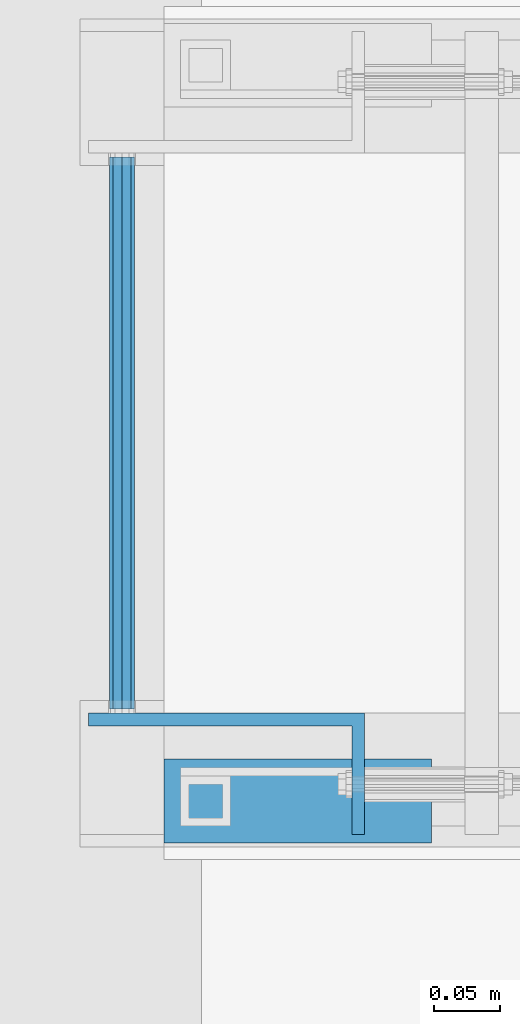
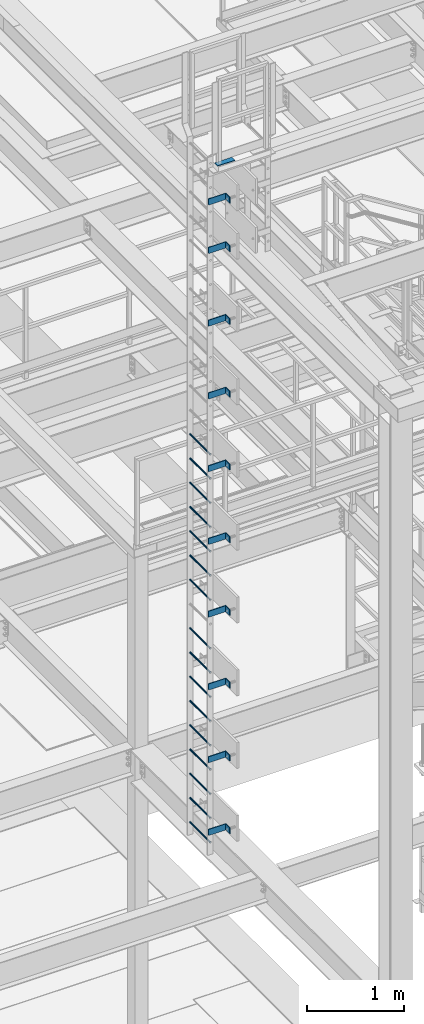
# One storey, part 2056 of 3843: 27 beams, 2 elements without a shape of their own.
"""IFC2X3 building model written with IfcOpenShell, lengths in millimetres."""

from ifc_helpers import new_model, si_unit, frame, origin_with_axes, place, context, subcontext, project, spatial, faceted_brep, material, type_object, element, aggregate, save


model = new_model("IFC2X3")

# Units and contexts
model_context = context("Model", 3, precision=1e-05, world=origin_with_axes())
body_context = subcontext(model_context, "Body", "Model", "MODEL_VIEW")
ifc_project = project(units=[si_unit("LENGTHUNIT", "METRE", prefix="MILLI"), si_unit("AREAUNIT", "SQUARE_METRE"), si_unit("VOLUMEUNIT", "CUBIC_METRE"), si_unit("MASSUNIT", "GRAM", prefix="KILO"), si_unit("TIMEUNIT", "SECOND"), si_unit("PLANEANGLEUNIT", "RADIAN"), si_unit("SOLIDANGLEUNIT", "STERADIAN"), si_unit("THERMODYNAMICTEMPERATUREUNIT", "DEGREE_CELSIUS"), si_unit("LUMINOUSINTENSITYUNIT", "LUMEN")], contexts=[model_context])

# Site, building, storey
site_placement = place(None, origin_with_axes())
site = spatial("IfcSite", under=ifc_project, at=site_placement, CompositionType="ELEMENT")
building_placement = place(site_placement, origin_with_axes())
building = spatial("IfcBuilding", under=site, at=building_placement, Name="Undefined", CompositionType="ELEMENT")
storey_placement = place(building_placement, origin_with_axes())
storey = spatial("IfcBuildingStorey", under=building, at=storey_placement, Name="Undefined", CompositionType="ELEMENT", Elevation=0.0)

# Assembly, beams
assembly_1_placement = place(storey_placement, origin_with_axes())
assembly_1 = element("IfcElementAssembly", 1, at=assembly_1_placement, inside=storey, Name="LADDER", AssemblyPlace="NOTDEFINED", PredefinedType="RIGID_FRAME")
ifc_material_1 = material(Name="STEEL/A36")
beam_type_1 = type_object("IfcBeamType", PredefinedType="NOTDEFINED")
beam_1_placement = place(assembly_1_placement, frame((48180.624987793, 17435.5125, 43630.85), z_axis=(0.0, 0.0, 1.0), x_axis=(1.0, 0.0, 0.0)))
beam_1 = element("IfcBeam", 2, at=beam_1_placement, type_object=beam_type_1, material=ifc_material_1, Name="BENT_PLATE", context=body_context, shape_type="Brep", body=[
    faceted_brep([(0.0, -4.76250000000073, -38.0999999999985), (0.0, -4.76250000000073, 38.0999999999985), (0.0, 4.76250000000073, 38.0999999999985), (0.0, 4.76250000000073, -38.0999999999985), (209.549999999996, 4.76249999999345, 38.0999999999985), (209.549999999996, 4.76249999999345, -38.0999999999985), (200.024999999994, -4.762500000008, -38.0999999999985), (200.024999999994, -4.762500000008, 38.0999999999985), (209.549999999996, -87.3125, 38.0999999999985), (209.549999999996, -87.3125, -38.0999999999985), (200.024999999994, -87.3125, 38.0999999999985), (200.024999999994, -87.3125, -38.0999999999985)], [[[0, 1, 2, 3]], [[3, 2, 4, 5]], [[1, 0, 6, 7]], [[5, 4, 8, 9]], [[4, 2, 1, 7, 10, 8]], [[7, 6, 11, 10]], [[6, 0, 3, 5, 9, 11]], [[10, 11, 9, 8]]]),
])
beam_2_placement = place(assembly_1_placement, frame((48180.6249877929, 17435.5125, 43021.25), z_axis=(0.0, 0.0, 1.0), x_axis=(1.0, 0.0, 0.0)))
beam_2 = element("IfcBeam", 3, at=beam_2_placement, type_object=beam_type_1, material=ifc_material_1, Name="BENT_PLATE", context=body_context, shape_type="Brep", body=[
    faceted_brep([(0.0, -4.76250000000073, -38.0999999999985), (0.0, -4.76250000000073, 38.0999999999985), (0.0, 4.76250000000073, 38.0999999999985), (0.0, 4.76250000000073, -38.0999999999985), (209.549999999996, 4.76249999999345, 38.0999999999985), (209.549999999996, 4.76249999999345, -38.0999999999985), (200.024999999994, -4.762500000008, -38.0999999999985), (200.024999999994, -4.762500000008, 38.0999999999985), (209.549999999996, -87.3125, 38.0999999999985), (209.549999999996, -87.3125, -38.0999999999985), (200.024999999994, -87.3125, 38.0999999999985), (200.024999999994, -87.3125, -38.0999999999985)], [[[0, 1, 2, 3]], [[3, 2, 4, 5]], [[1, 0, 6, 7]], [[5, 4, 8, 9]], [[4, 2, 1, 7, 10, 8]], [[7, 6, 11, 10]], [[6, 0, 3, 5, 9, 11]], [[10, 11, 9, 8]]]),
])
beam_3_placement = place(assembly_1_placement, frame((48180.6249877929, 17435.5125, 42106.85), z_axis=(0.0, 0.0, 1.0), x_axis=(1.0, 0.0, 0.0)))
beam_3 = element("IfcBeam", 4, at=beam_3_placement, type_object=beam_type_1, material=ifc_material_1, Name="BENT_PLATE", context=body_context, shape_type="Brep", body=[
    faceted_brep([(0.0, -4.76250000000073, -38.0999999999985), (0.0, -4.76250000000073, 38.0999999999985), (0.0, 4.76250000000073, 38.0999999999985), (0.0, 4.76250000000073, -38.0999999999985), (209.549999999996, 4.76249999999345, 38.0999999999985), (209.549999999996, 4.76249999999345, -38.0999999999985), (200.024999999994, -4.762500000008, -38.0999999999985), (200.024999999994, -4.762500000008, 38.0999999999985), (209.549999999996, -87.3125, 38.0999999999985), (209.549999999996, -87.3125, -38.0999999999985), (200.024999999994, -87.3125, 38.0999999999985), (200.024999999994, -87.3125, -38.0999999999985)], [[[0, 1, 2, 3]], [[3, 2, 4, 5]], [[1, 0, 6, 7]], [[5, 4, 8, 9]], [[4, 2, 1, 7, 10, 8]], [[7, 6, 11, 10]], [[6, 0, 3, 5, 9, 11]], [[10, 11, 9, 8]]]),
])
beam_4_placement = place(assembly_1_placement, frame((48180.6249877929, 17435.5125, 41192.45), z_axis=(0.0, 0.0, 1.0), x_axis=(1.0, 0.0, 0.0)))
beam_4 = element("IfcBeam", 5, at=beam_4_placement, type_object=beam_type_1, material=ifc_material_1, Name="BENT_PLATE", context=body_context, shape_type="Brep", body=[
    faceted_brep([(0.0, -4.76250000000073, -38.0999999999985), (0.0, -4.76250000000073, 38.0999999999985), (0.0, 4.76250000000073, 38.0999999999985), (0.0, 4.76250000000073, -38.0999999999985), (209.549999999996, 4.76249999999345, 38.0999999999985), (209.549999999996, 4.76249999999345, -38.0999999999985), (200.024999999994, -4.762500000008, -38.0999999999985), (200.024999999994, -4.762500000008, 38.0999999999985), (209.549999999996, -87.3125, 38.0999999999985), (209.549999999996, -87.3125, -38.0999999999985), (200.024999999994, -87.3125, 38.0999999999985), (200.024999999994, -87.3125, -38.0999999999985)], [[[0, 1, 2, 3]], [[3, 2, 4, 5]], [[1, 0, 6, 7]], [[5, 4, 8, 9]], [[4, 2, 1, 7, 10, 8]], [[7, 6, 11, 10]], [[6, 0, 3, 5, 9, 11]], [[10, 11, 9, 8]]]),
])
beam_5_placement = place(assembly_1_placement, frame((48180.6249877929, 17435.5125, 40278.05), z_axis=(0.0, 0.0, 1.0), x_axis=(1.0, 0.0, 0.0)))
beam_5 = element("IfcBeam", 6, at=beam_5_placement, type_object=beam_type_1, material=ifc_material_1, Name="BENT_PLATE", context=body_context, shape_type="Brep", body=[
    faceted_brep([(0.0, -4.76250000000073, -38.0999999999985), (0.0, -4.76250000000073, 38.0999999999985), (0.0, 4.76250000000073, 38.0999999999985), (0.0, 4.76250000000073, -38.0999999999985), (209.549999999996, 4.76249999999345, 38.0999999999985), (209.549999999996, 4.76249999999345, -38.0999999999985), (200.024999999994, -4.762500000008, -38.0999999999985), (200.024999999994, -4.762500000008, 38.0999999999985), (209.549999999996, -87.3125, 38.0999999999985), (209.549999999996, -87.3125, -38.0999999999985), (200.024999999994, -87.3125, 38.0999999999985), (200.024999999994, -87.3125, -38.0999999999985)], [[[0, 1, 2, 3]], [[3, 2, 4, 5]], [[1, 0, 6, 7]], [[5, 4, 8, 9]], [[4, 2, 1, 7, 10, 8]], [[7, 6, 11, 10]], [[6, 0, 3, 5, 9, 11]], [[10, 11, 9, 8]]]),
])
beam_6_placement = place(assembly_1_placement, frame((48180.6249877929, 17435.5125, 39363.65), z_axis=(0.0, 0.0, 1.0), x_axis=(1.0, 0.0, 0.0)))
beam_6 = element("IfcBeam", 7, at=beam_6_placement, type_object=beam_type_1, material=ifc_material_1, Name="BENT_PLATE", context=body_context, shape_type="Brep", body=[
    faceted_brep([(0.0, -4.76250000000073, -38.0999999999985), (0.0, -4.76250000000073, 38.0999999999985), (0.0, 4.76250000000073, 38.0999999999985), (0.0, 4.76250000000073, -38.0999999999985), (209.549999999996, 4.76249999999345, 38.0999999999985), (209.549999999996, 4.76249999999345, -38.0999999999985), (200.024999999994, -4.762500000008, -38.0999999999985), (200.024999999994, -4.762500000008, 38.0999999999985), (209.549999999996, -87.3125, 38.0999999999985), (209.549999999996, -87.3125, -38.0999999999985), (200.024999999994, -87.3125, 38.0999999999985), (200.024999999994, -87.3125, -38.0999999999985)], [[[0, 1, 2, 3]], [[3, 2, 4, 5]], [[1, 0, 6, 7]], [[5, 4, 8, 9]], [[4, 2, 1, 7, 10, 8]], [[7, 6, 11, 10]], [[6, 0, 3, 5, 9, 11]], [[10, 11, 9, 8]]]),
])
beam_7_placement = place(assembly_1_placement, frame((48180.6249877929, 17435.5125, 38449.25), z_axis=(0.0, 0.0, 1.0), x_axis=(1.0, 0.0, 0.0)))
beam_7 = element("IfcBeam", 8, at=beam_7_placement, type_object=beam_type_1, material=ifc_material_1, Name="BENT_PLATE", context=body_context, shape_type="Brep", body=[
    faceted_brep([(0.0, -4.76250000000073, -38.0999999999985), (0.0, -4.76250000000073, 38.0999999999985), (0.0, 4.76250000000073, 38.0999999999985), (0.0, 4.76250000000073, -38.0999999999985), (209.549999999996, 4.76249999999345, 38.0999999999985), (209.549999999996, 4.76249999999345, -38.0999999999985), (200.024999999994, -4.762500000008, -38.0999999999985), (200.024999999994, -4.762500000008, 38.0999999999985), (209.549999999996, -87.3125, 38.0999999999985), (209.549999999996, -87.3125, -38.0999999999985), (200.024999999994, -87.3125, 38.0999999999985), (200.024999999994, -87.3125, -38.0999999999985)], [[[0, 1, 2, 3]], [[3, 2, 4, 5]], [[1, 0, 6, 7]], [[5, 4, 8, 9]], [[4, 2, 1, 7, 10, 8]], [[7, 6, 11, 10]], [[6, 0, 3, 5, 9, 11]], [[10, 11, 9, 8]]]),
])
beam_8_placement = place(assembly_1_placement, frame((48180.6249877929, 17435.5125, 37534.85), z_axis=(0.0, 0.0, 1.0), x_axis=(1.0, 0.0, 0.0)))
beam_8 = element("IfcBeam", 9, at=beam_8_placement, type_object=beam_type_1, material=ifc_material_1, Name="BENT_PLATE", context=body_context, shape_type="Brep", body=[
    faceted_brep([(0.0, -4.76250000000073, -38.0999999999985), (0.0, -4.76250000000073, 38.0999999999985), (0.0, 4.76250000000073, 38.0999999999985), (0.0, 4.76250000000073, -38.0999999999985), (209.549999999996, 4.76249999999345, 38.0999999999985), (209.549999999996, 4.76249999999345, -38.0999999999985), (200.024999999994, -4.762500000008, -38.0999999999985), (200.024999999994, -4.762500000008, 38.0999999999985), (209.549999999996, -87.3125, 38.0999999999985), (209.549999999996, -87.3125, -38.0999999999985), (200.024999999994, -87.3125, 38.0999999999985), (200.024999999994, -87.3125, -38.0999999999985)], [[[0, 1, 2, 3]], [[3, 2, 4, 5]], [[1, 0, 6, 7]], [[5, 4, 8, 9]], [[4, 2, 1, 7, 10, 8]], [[7, 6, 11, 10]], [[6, 0, 3, 5, 9, 11]], [[10, 11, 9, 8]]]),
])
beam_9_placement = place(assembly_1_placement, frame((48180.6249877929, 17435.5125, 36620.45), z_axis=(0.0, 0.0, 1.0), x_axis=(1.0, 0.0, 0.0)))
beam_9 = element("IfcBeam", 10, at=beam_9_placement, type_object=beam_type_1, material=ifc_material_1, Name="BENT_PLATE", context=body_context, shape_type="Brep", body=[
    faceted_brep([(0.0, -4.76250000000073, -38.0999999999985), (0.0, -4.76250000000073, 38.0999999999985), (0.0, 4.76250000000073, 38.0999999999985), (0.0, 4.76250000000073, -38.0999999999985), (209.549999999996, 4.76249999999345, 38.0999999999985), (209.549999999996, 4.76249999999345, -38.0999999999985), (200.024999999994, -4.762500000008, -38.0999999999985), (200.024999999994, -4.762500000008, 38.0999999999985), (209.549999999996, -87.3125, 38.0999999999985), (209.549999999996, -87.3125, -38.0999999999985), (200.024999999994, -87.3125, 38.0999999999985), (200.024999999994, -87.3125, -38.0999999999985)], [[[0, 1, 2, 3]], [[3, 2, 4, 5]], [[1, 0, 6, 7]], [[5, 4, 8, 9]], [[4, 2, 1, 7, 10, 8]], [[7, 6, 11, 10]], [[6, 0, 3, 5, 9, 11]], [[10, 11, 9, 8]]]),
])
beam_10_placement = place(assembly_1_placement, frame((48180.6249877929, 17435.5125, 35706.05), z_axis=(0.0, 0.0, 1.0), x_axis=(1.0, 0.0, 0.0)))
beam_10 = element("IfcBeam", 11, at=beam_10_placement, type_object=beam_type_1, material=ifc_material_1, Name="BENT_PLATE", context=body_context, shape_type="Brep", body=[
    faceted_brep([(0.0, -4.76250000000073, -38.0999999999985), (0.0, -4.76250000000073, 38.0999999999985), (0.0, 4.76250000000073, 38.0999999999985), (0.0, 4.76250000000073, -38.0999999999985), (209.549999999996, 4.76249999999345, 38.0999999999985), (209.549999999996, 4.76249999999345, -38.0999999999985), (200.024999999994, -4.762500000008, -38.0999999999985), (200.024999999994, -4.762500000008, 38.0999999999985), (209.549999999996, -87.3125, 38.0999999999985), (209.549999999996, -87.3125, -38.0999999999985), (200.024999999994, -87.3125, 38.0999999999985), (200.024999999994, -87.3125, -38.0999999999985)], [[[0, 1, 2, 3]], [[3, 2, 4, 5]], [[1, 0, 6, 7]], [[5, 4, 8, 9]], [[4, 2, 1, 7, 10, 8]], [[7, 6, 11, 10]], [[6, 0, 3, 5, 9, 11]], [[10, 11, 9, 8]]]),
])
ifc_material_2 = material(Name="STEEL/A572-50")
beam_type_2 = type_object("IfcBeamType", PredefinedType="NOTDEFINED")
beam_11_placement = place(assembly_1_placement, frame((48206.024987793, 17862.55, 35569.525), z_axis=(1.0, 0.0, 0.0), x_axis=(0.0, -1.0, 0.0)))
beam_11 = element("IfcBeam", 12, at=beam_11_placement, type_object=beam_type_2, material=ifc_material_2, Name="RUNG", context=body_context, shape_type="Brep", body=[
    faceted_brep([(0.0, -9.52500000000146, 0.0), (0.0, -6.73519209080405, -6.73519209079677), (419.100000000006, -6.73519209080405, -6.73519209079677), (419.100000000006, -9.52500000000146, 0.0), (2.95075507493764e-12, 2.91322521661641e-12, -9.52499961853027), (419.100000000006, 0.0, -9.52499999999418), (0.0, 6.73519209080405, -6.73519209079677), (419.100000000006, 6.73519209080405, -6.73519209079677), (0.0, 9.52500000000146, 0.0), (419.100000000006, 9.52500000000146, 0.0), (0.0, 6.73519209080405, 6.73519209079677), (419.100000000006, 6.73519209080405, 6.73519209079677), (-9.87109982941227e-13, 2.91322521661641e-12, 9.52499961853027), (419.100000000006, 0.0, 9.52499999999418), (0.0, -6.73519209080405, 6.73519209079677), (419.100000000006, -6.73519209080405, 6.73519209079677)], [[[0, 1, 2, 3]], [[1, 4, 5, 2]], [[4, 6, 7, 5]], [[6, 8, 9, 7]], [[8, 10, 11, 9]], [[10, 12, 13, 11]], [[12, 14, 15, 13]], [[14, 0, 3, 15]], [[5, 7, 9, 11, 13, 15, 3, 2]], [[14, 12, 10, 8, 6, 4, 1, 0]]]),
])
beam_12_placement = place(assembly_1_placement, frame((48206.024987793, 17862.55, 35874.325), z_axis=(1.0, 0.0, 0.0), x_axis=(0.0, -1.0, 0.0)))
beam_12 = element("IfcBeam", 13, at=beam_12_placement, type_object=beam_type_2, material=ifc_material_2, Name="RUNG", context=body_context, shape_type="Brep", body=[
    faceted_brep([(0.0, -9.52500000000146, 0.0), (0.0, -6.73519209080405, -6.73519209079677), (419.100000000006, -6.73519209080405, -6.73519209079677), (419.100000000006, -9.52500000000146, 0.0), (2.95075507493764e-12, 2.91322521661641e-12, -9.52499961853027), (419.100000000006, 0.0, -9.52499999999418), (0.0, 6.73519209080405, -6.73519209079677), (419.100000000006, 6.73519209080405, -6.73519209079677), (0.0, 9.52500000000146, 0.0), (419.100000000006, 9.52500000000146, 0.0), (0.0, 6.73519209080405, 6.73519209079677), (419.100000000006, 6.73519209080405, 6.73519209079677), (-9.87109982941227e-13, 2.91322521661641e-12, 9.52499961853027), (419.100000000006, 0.0, 9.52499999999418), (0.0, -6.73519209080405, 6.73519209079677), (419.100000000006, -6.73519209080405, 6.73519209079677)], [[[0, 1, 2, 3]], [[1, 4, 5, 2]], [[4, 6, 7, 5]], [[6, 8, 9, 7]], [[8, 10, 11, 9]], [[10, 12, 13, 11]], [[12, 14, 15, 13]], [[14, 0, 3, 15]], [[5, 7, 9, 11, 13, 15, 3, 2]], [[14, 12, 10, 8, 6, 4, 1, 0]]]),
])
beam_13_placement = place(assembly_1_placement, frame((48206.024987793, 17862.55, 36179.125), z_axis=(1.0, 0.0, 0.0), x_axis=(0.0, -1.0, 0.0)))
beam_13 = element("IfcBeam", 14, at=beam_13_placement, type_object=beam_type_2, material=ifc_material_2, Name="RUNG", context=body_context, shape_type="Brep", body=[
    faceted_brep([(0.0, -9.52500000000146, 0.0), (0.0, -6.73519209080405, -6.73519209079677), (419.100000000006, -6.73519209080405, -6.73519209079677), (419.100000000006, -9.52500000000146, 0.0), (2.95075507493764e-12, 2.91322521661641e-12, -9.52499961853027), (419.100000000006, 0.0, -9.52499999999418), (0.0, 6.73519209080405, -6.73519209079677), (419.100000000006, 6.73519209080405, -6.73519209079677), (0.0, 9.52500000000146, 0.0), (419.100000000006, 9.52500000000146, 0.0), (0.0, 6.73519209080405, 6.73519209079677), (419.100000000006, 6.73519209080405, 6.73519209079677), (-9.87109982941227e-13, 2.91322521661641e-12, 9.52499961853027), (419.100000000006, 0.0, 9.52499999999418), (0.0, -6.73519209080405, 6.73519209079677), (419.100000000006, -6.73519209080405, 6.73519209079677)], [[[0, 1, 2, 3]], [[1, 4, 5, 2]], [[4, 6, 7, 5]], [[6, 8, 9, 7]], [[8, 10, 11, 9]], [[10, 12, 13, 11]], [[12, 14, 15, 13]], [[14, 0, 3, 15]], [[5, 7, 9, 11, 13, 15, 3, 2]], [[14, 12, 10, 8, 6, 4, 1, 0]]]),
])
beam_14_placement = place(assembly_1_placement, frame((48206.024987793, 17862.55, 36483.925), z_axis=(1.0, 0.0, 0.0), x_axis=(0.0, -1.0, 0.0)))
beam_14 = element("IfcBeam", 15, at=beam_14_placement, type_object=beam_type_2, material=ifc_material_2, Name="RUNG", context=body_context, shape_type="Brep", body=[
    faceted_brep([(0.0, -9.52500000000146, 0.0), (0.0, -6.73519209080405, -6.73519209079677), (419.100000000006, -6.73519209080405, -6.73519209079677), (419.100000000006, -9.52500000000146, 0.0), (2.95075507493764e-12, 2.91322521661641e-12, -9.52499961853027), (419.100000000006, 0.0, -9.52499999999418), (0.0, 6.73519209080405, -6.73519209079677), (419.100000000006, 6.73519209080405, -6.73519209079677), (0.0, 9.52500000000146, 0.0), (419.100000000006, 9.52500000000146, 0.0), (0.0, 6.73519209080405, 6.73519209079677), (419.100000000006, 6.73519209080405, 6.73519209079677), (-9.87109982941227e-13, 2.91322521661641e-12, 9.52499961853027), (419.100000000006, 0.0, 9.52499999999418), (0.0, -6.73519209080405, 6.73519209079677), (419.100000000006, -6.73519209080405, 6.73519209079677)], [[[0, 1, 2, 3]], [[1, 4, 5, 2]], [[4, 6, 7, 5]], [[6, 8, 9, 7]], [[8, 10, 11, 9]], [[10, 12, 13, 11]], [[12, 14, 15, 13]], [[14, 0, 3, 15]], [[5, 7, 9, 11, 13, 15, 3, 2]], [[14, 12, 10, 8, 6, 4, 1, 0]]]),
])
beam_15_placement = place(assembly_1_placement, frame((48206.024987793, 17862.55, 36788.725), z_axis=(1.0, 0.0, 0.0), x_axis=(0.0, -1.0, 0.0)))
beam_15 = element("IfcBeam", 16, at=beam_15_placement, type_object=beam_type_2, material=ifc_material_2, Name="RUNG", context=body_context, shape_type="Brep", body=[
    faceted_brep([(0.0, -9.52500000000146, 0.0), (0.0, -6.73519209080405, -6.73519209079677), (419.100000000006, -6.73519209080405, -6.73519209079677), (419.100000000006, -9.52500000000146, 0.0), (2.95075507493764e-12, 2.91322521661641e-12, -9.52499961853027), (419.100000000006, 0.0, -9.52499999999418), (0.0, 6.73519209080405, -6.73519209079677), (419.100000000006, 6.73519209080405, -6.73519209079677), (0.0, 9.52500000000146, 0.0), (419.100000000006, 9.52500000000146, 0.0), (0.0, 6.73519209080405, 6.73519209079677), (419.100000000006, 6.73519209080405, 6.73519209079677), (-9.87109982941227e-13, 2.91322521661641e-12, 9.52499961853027), (419.100000000006, 0.0, 9.52499999999418), (0.0, -6.73519209080405, 6.73519209079677), (419.100000000006, -6.73519209080405, 6.73519209079677)], [[[0, 1, 2, 3]], [[1, 4, 5, 2]], [[4, 6, 7, 5]], [[6, 8, 9, 7]], [[8, 10, 11, 9]], [[10, 12, 13, 11]], [[12, 14, 15, 13]], [[14, 0, 3, 15]], [[5, 7, 9, 11, 13, 15, 3, 2]], [[14, 12, 10, 8, 6, 4, 1, 0]]]),
])
beam_16_placement = place(assembly_1_placement, frame((48206.024987793, 17862.55, 37093.525), z_axis=(1.0, 0.0, 0.0), x_axis=(0.0, -1.0, 0.0)))
beam_16 = element("IfcBeam", 17, at=beam_16_placement, type_object=beam_type_2, material=ifc_material_2, Name="RUNG", context=body_context, shape_type="Brep", body=[
    faceted_brep([(0.0, -9.52500000000146, 0.0), (0.0, -6.73519209080405, -6.73519209079677), (419.100000000006, -6.73519209080405, -6.73519209079677), (419.100000000006, -9.52500000000146, 0.0), (2.95075507493764e-12, 2.91322521661641e-12, -9.52499961853027), (419.100000000006, 0.0, -9.52499999999418), (0.0, 6.73519209080405, -6.73519209079677), (419.100000000006, 6.73519209080405, -6.73519209079677), (0.0, 9.52500000000146, 0.0), (419.100000000006, 9.52500000000146, 0.0), (0.0, 6.73519209080405, 6.73519209079677), (419.100000000006, 6.73519209080405, 6.73519209079677), (-9.87109982941227e-13, 2.91322521661641e-12, 9.52499961853027), (419.100000000006, 0.0, 9.52499999999418), (0.0, -6.73519209080405, 6.73519209079677), (419.100000000006, -6.73519209080405, 6.73519209079677)], [[[0, 1, 2, 3]], [[1, 4, 5, 2]], [[4, 6, 7, 5]], [[6, 8, 9, 7]], [[8, 10, 11, 9]], [[10, 12, 13, 11]], [[12, 14, 15, 13]], [[14, 0, 3, 15]], [[5, 7, 9, 11, 13, 15, 3, 2]], [[14, 12, 10, 8, 6, 4, 1, 0]]]),
])
beam_17_placement = place(assembly_1_placement, frame((48206.024987793, 17862.55, 37398.325), z_axis=(1.0, 0.0, 0.0), x_axis=(0.0, -1.0, 0.0)))
beam_17 = element("IfcBeam", 18, at=beam_17_placement, type_object=beam_type_2, material=ifc_material_2, Name="RUNG", context=body_context, shape_type="Brep", body=[
    faceted_brep([(0.0, -9.52500000000146, 0.0), (0.0, -6.73519209080405, -6.73519209079677), (419.100000000006, -6.73519209080405, -6.73519209079677), (419.100000000006, -9.52500000000146, 0.0), (2.95075507493764e-12, 2.91322521661641e-12, -9.52499961853027), (419.100000000006, 0.0, -9.52499999999418), (0.0, 6.73519209080405, -6.73519209079677), (419.100000000006, 6.73519209080405, -6.73519209079677), (0.0, 9.52500000000146, 0.0), (419.100000000006, 9.52500000000146, 0.0), (0.0, 6.73519209080405, 6.73519209079677), (419.100000000006, 6.73519209080405, 6.73519209079677), (-9.87109982941227e-13, 2.91322521661641e-12, 9.52499961853027), (419.100000000006, 0.0, 9.52499999999418), (0.0, -6.73519209080405, 6.73519209079677), (419.100000000006, -6.73519209080405, 6.73519209079677)], [[[0, 1, 2, 3]], [[1, 4, 5, 2]], [[4, 6, 7, 5]], [[6, 8, 9, 7]], [[8, 10, 11, 9]], [[10, 12, 13, 11]], [[12, 14, 15, 13]], [[14, 0, 3, 15]], [[5, 7, 9, 11, 13, 15, 3, 2]], [[14, 12, 10, 8, 6, 4, 1, 0]]]),
])
beam_18_placement = place(assembly_1_placement, frame((48206.024987793, 17862.55, 37703.125), z_axis=(1.0, 0.0, 0.0), x_axis=(0.0, -1.0, 0.0)))
beam_18 = element("IfcBeam", 19, at=beam_18_placement, type_object=beam_type_2, material=ifc_material_2, Name="RUNG", context=body_context, shape_type="Brep", body=[
    faceted_brep([(0.0, -9.52500000000146, 0.0), (0.0, -6.73519209080405, -6.73519209079677), (419.100000000006, -6.73519209080405, -6.73519209079677), (419.100000000006, -9.52500000000146, 0.0), (2.95075507493764e-12, 2.91322521661641e-12, -9.52499961853027), (419.100000000006, 0.0, -9.52499999999418), (0.0, 6.73519209080405, -6.73519209079677), (419.100000000006, 6.73519209080405, -6.73519209079677), (0.0, 9.52500000000146, 0.0), (419.100000000006, 9.52500000000146, 0.0), (0.0, 6.73519209080405, 6.73519209079677), (419.100000000006, 6.73519209080405, 6.73519209079677), (-9.87109982941227e-13, 2.91322521661641e-12, 9.52499961853027), (419.100000000006, 0.0, 9.52499999999418), (0.0, -6.73519209080405, 6.73519209079677), (419.100000000006, -6.73519209080405, 6.73519209079677)], [[[0, 1, 2, 3]], [[1, 4, 5, 2]], [[4, 6, 7, 5]], [[6, 8, 9, 7]], [[8, 10, 11, 9]], [[10, 12, 13, 11]], [[12, 14, 15, 13]], [[14, 0, 3, 15]], [[5, 7, 9, 11, 13, 15, 3, 2]], [[14, 12, 10, 8, 6, 4, 1, 0]]]),
])
beam_19_placement = place(assembly_1_placement, frame((48206.024987793, 17862.55, 40446.325), z_axis=(1.0, 0.0, 0.0), x_axis=(0.0, -1.0, 0.0)))
beam_19 = element("IfcBeam", 20, at=beam_19_placement, type_object=beam_type_2, material=ifc_material_2, Name="RUNG", context=body_context, shape_type="Brep", body=[
    faceted_brep([(0.0, -9.52500000000146, 0.0), (0.0, -6.73519209080405, -6.73519209079677), (419.100000000006, -6.73519209080405, -6.73519209079677), (419.100000000006, -9.52500000000146, 0.0), (2.95075507493764e-12, 2.91322521661641e-12, -9.52499961853027), (419.100000000006, 0.0, -9.52499999999418), (0.0, 6.73519209080405, -6.73519209079677), (419.100000000006, 6.73519209080405, -6.73519209079677), (0.0, 9.52500000000146, 0.0), (419.100000000006, 9.52500000000146, 0.0), (0.0, 6.73519209080405, 6.73519209079677), (419.100000000006, 6.73519209080405, 6.73519209079677), (-9.87109982941227e-13, 2.91322521661641e-12, 9.52499961853027), (419.100000000006, 0.0, 9.52499999999418), (0.0, -6.73519209080405, 6.73519209079677), (419.100000000006, -6.73519209080405, 6.73519209079677)], [[[0, 1, 2, 3]], [[1, 4, 5, 2]], [[4, 6, 7, 5]], [[6, 8, 9, 7]], [[8, 10, 11, 9]], [[10, 12, 13, 11]], [[12, 14, 15, 13]], [[14, 0, 3, 15]], [[5, 7, 9, 11, 13, 15, 3, 2]], [[14, 12, 10, 8, 6, 4, 1, 0]]]),
])
beam_20_placement = place(assembly_1_placement, frame((48206.024987793, 17862.55, 38007.925), z_axis=(1.0, 0.0, 0.0), x_axis=(0.0, -1.0, 0.0)))
beam_20 = element("IfcBeam", 21, at=beam_20_placement, type_object=beam_type_2, material=ifc_material_2, Name="RUNG", context=body_context, shape_type="Brep", body=[
    faceted_brep([(0.0, -9.52500000000146, 0.0), (0.0, -6.73519209080405, -6.73519209079677), (419.100000000006, -6.73519209080405, -6.73519209079677), (419.100000000006, -9.52500000000146, 0.0), (2.95075507493764e-12, 2.91322521661641e-12, -9.52499961853027), (419.100000000006, 0.0, -9.52499999999418), (0.0, 6.73519209080405, -6.73519209079677), (419.100000000006, 6.73519209080405, -6.73519209079677), (0.0, 9.52500000000146, 0.0), (419.100000000006, 9.52500000000146, 0.0), (0.0, 6.73519209080405, 6.73519209079677), (419.100000000006, 6.73519209080405, 6.73519209079677), (-9.87109982941227e-13, 2.91322521661641e-12, 9.52499961853027), (419.100000000006, 0.0, 9.52499999999418), (0.0, -6.73519209080405, 6.73519209079677), (419.100000000006, -6.73519209080405, 6.73519209079677)], [[[0, 1, 2, 3]], [[1, 4, 5, 2]], [[4, 6, 7, 5]], [[6, 8, 9, 7]], [[8, 10, 11, 9]], [[10, 12, 13, 11]], [[12, 14, 15, 13]], [[14, 0, 3, 15]], [[5, 7, 9, 11, 13, 15, 3, 2]], [[14, 12, 10, 8, 6, 4, 1, 0]]]),
])
beam_21_placement = place(assembly_1_placement, frame((48206.024987793, 17862.55, 38617.525), z_axis=(1.0, 0.0, 0.0), x_axis=(0.0, -1.0, 0.0)))
beam_21 = element("IfcBeam", 22, at=beam_21_placement, type_object=beam_type_2, material=ifc_material_2, Name="RUNG", context=body_context, shape_type="Brep", body=[
    faceted_brep([(0.0, -9.52500000000146, 0.0), (0.0, -6.73519209080405, -6.73519209079677), (419.100000000006, -6.73519209080405, -6.73519209079677), (419.100000000006, -9.52500000000146, 0.0), (2.95075507493764e-12, 2.91322521661641e-12, -9.52499961853027), (419.100000000006, 0.0, -9.52499999999418), (0.0, 6.73519209080405, -6.73519209079677), (419.100000000006, 6.73519209080405, -6.73519209079677), (0.0, 9.52500000000146, 0.0), (419.100000000006, 9.52500000000146, 0.0), (0.0, 6.73519209080405, 6.73519209079677), (419.100000000006, 6.73519209080405, 6.73519209079677), (-9.87109982941227e-13, 2.91322521661641e-12, 9.52499961853027), (419.100000000006, 0.0, 9.52499999999418), (0.0, -6.73519209080405, 6.73519209079677), (419.100000000006, -6.73519209080405, 6.73519209079677)], [[[0, 1, 2, 3]], [[1, 4, 5, 2]], [[4, 6, 7, 5]], [[6, 8, 9, 7]], [[8, 10, 11, 9]], [[10, 12, 13, 11]], [[12, 14, 15, 13]], [[14, 0, 3, 15]], [[5, 7, 9, 11, 13, 15, 3, 2]], [[14, 12, 10, 8, 6, 4, 1, 0]]]),
])
beam_22_placement = place(assembly_1_placement, frame((48206.024987793, 17862.55, 38922.325), z_axis=(1.0, 0.0, 0.0), x_axis=(0.0, -1.0, 0.0)))
beam_22 = element("IfcBeam", 23, at=beam_22_placement, type_object=beam_type_2, material=ifc_material_2, Name="RUNG", context=body_context, shape_type="Brep", body=[
    faceted_brep([(0.0, -9.52500000000146, 0.0), (0.0, -6.73519209080405, -6.73519209079677), (419.100000000006, -6.73519209080405, -6.73519209079677), (419.100000000006, -9.52500000000146, 0.0), (2.95075507493764e-12, 2.91322521661641e-12, -9.52499961853027), (419.100000000006, 0.0, -9.52499999999418), (0.0, 6.73519209080405, -6.73519209079677), (419.100000000006, 6.73519209080405, -6.73519209079677), (0.0, 9.52500000000146, 0.0), (419.100000000006, 9.52500000000146, 0.0), (0.0, 6.73519209080405, 6.73519209079677), (419.100000000006, 6.73519209080405, 6.73519209079677), (-9.87109982941227e-13, 2.91322521661641e-12, 9.52499961853027), (419.100000000006, 0.0, 9.52499999999418), (0.0, -6.73519209080405, 6.73519209079677), (419.100000000006, -6.73519209080405, 6.73519209079677)], [[[0, 1, 2, 3]], [[1, 4, 5, 2]], [[4, 6, 7, 5]], [[6, 8, 9, 7]], [[8, 10, 11, 9]], [[10, 12, 13, 11]], [[12, 14, 15, 13]], [[14, 0, 3, 15]], [[5, 7, 9, 11, 13, 15, 3, 2]], [[14, 12, 10, 8, 6, 4, 1, 0]]]),
])
beam_23_placement = place(assembly_1_placement, frame((48206.024987793, 17862.55, 39227.125), z_axis=(1.0, 0.0, 0.0), x_axis=(0.0, -1.0, 0.0)))
beam_23 = element("IfcBeam", 24, at=beam_23_placement, type_object=beam_type_2, material=ifc_material_2, Name="RUNG", context=body_context, shape_type="Brep", body=[
    faceted_brep([(0.0, -9.52500000000146, 0.0), (0.0, -6.73519209080405, -6.73519209079677), (419.100000000006, -6.73519209080405, -6.73519209079677), (419.100000000006, -9.52500000000146, 0.0), (2.95075507493764e-12, 2.91322521661641e-12, -9.52499961853027), (419.100000000006, 0.0, -9.52499999999418), (0.0, 6.73519209080405, -6.73519209079677), (419.100000000006, 6.73519209080405, -6.73519209079677), (0.0, 9.52500000000146, 0.0), (419.100000000006, 9.52500000000146, 0.0), (0.0, 6.73519209080405, 6.73519209079677), (419.100000000006, 6.73519209080405, 6.73519209079677), (-9.87109982941227e-13, 2.91322521661641e-12, 9.52499961853027), (419.100000000006, 0.0, 9.52499999999418), (0.0, -6.73519209080405, 6.73519209079677), (419.100000000006, -6.73519209080405, 6.73519209079677)], [[[0, 1, 2, 3]], [[1, 4, 5, 2]], [[4, 6, 7, 5]], [[6, 8, 9, 7]], [[8, 10, 11, 9]], [[10, 12, 13, 11]], [[12, 14, 15, 13]], [[14, 0, 3, 15]], [[5, 7, 9, 11, 13, 15, 3, 2]], [[14, 12, 10, 8, 6, 4, 1, 0]]]),
])
beam_24_placement = place(assembly_1_placement, frame((48206.024987793, 17862.55, 39531.925), z_axis=(1.0, 0.0, 0.0), x_axis=(0.0, -1.0, 0.0)))
beam_24 = element("IfcBeam", 25, at=beam_24_placement, type_object=beam_type_2, material=ifc_material_2, Name="RUNG", context=body_context, shape_type="Brep", body=[
    faceted_brep([(0.0, -9.52500000000146, 0.0), (0.0, -6.73519209080405, -6.73519209079677), (419.100000000006, -6.73519209080405, -6.73519209079677), (419.100000000006, -9.52500000000146, 0.0), (2.95075507493764e-12, 2.91322521661641e-12, -9.52499961853027), (419.100000000006, 0.0, -9.52499999999418), (0.0, 6.73519209080405, -6.73519209079677), (419.100000000006, 6.73519209080405, -6.73519209079677), (0.0, 9.52500000000146, 0.0), (419.100000000006, 9.52500000000146, 0.0), (0.0, 6.73519209080405, 6.73519209079677), (419.100000000006, 6.73519209080405, 6.73519209079677), (-9.87109982941227e-13, 2.91322521661641e-12, 9.52499961853027), (419.100000000006, 0.0, 9.52499999999418), (0.0, -6.73519209080405, 6.73519209079677), (419.100000000006, -6.73519209080405, 6.73519209079677)], [[[0, 1, 2, 3]], [[1, 4, 5, 2]], [[4, 6, 7, 5]], [[6, 8, 9, 7]], [[8, 10, 11, 9]], [[10, 12, 13, 11]], [[12, 14, 15, 13]], [[14, 0, 3, 15]], [[5, 7, 9, 11, 13, 15, 3, 2]], [[14, 12, 10, 8, 6, 4, 1, 0]]]),
])
beam_25_placement = place(assembly_1_placement, frame((48206.024987793, 17862.55, 39836.725), z_axis=(1.0, 0.0, 0.0), x_axis=(0.0, -1.0, 0.0)))
beam_25 = element("IfcBeam", 26, at=beam_25_placement, type_object=beam_type_2, material=ifc_material_2, Name="RUNG", context=body_context, shape_type="Brep", body=[
    faceted_brep([(0.0, -9.52500000000146, 0.0), (0.0, -6.73519209080405, -6.73519209079677), (419.100000000006, -6.73519209080405, -6.73519209079677), (419.100000000006, -9.52500000000146, 0.0), (2.95075507493764e-12, 2.91322521661641e-12, -9.52499961853027), (419.100000000006, 0.0, -9.52499999999418), (0.0, 6.73519209080405, -6.73519209079677), (419.100000000006, 6.73519209080405, -6.73519209079677), (0.0, 9.52500000000146, 0.0), (419.100000000006, 9.52500000000146, 0.0), (0.0, 6.73519209080405, 6.73519209079677), (419.100000000006, 6.73519209080405, 6.73519209079677), (-9.87109982941227e-13, 2.91322521661641e-12, 9.52499961853027), (419.100000000006, 0.0, 9.52499999999418), (0.0, -6.73519209080405, 6.73519209079677), (419.100000000006, -6.73519209080405, 6.73519209079677)], [[[0, 1, 2, 3]], [[1, 4, 5, 2]], [[4, 6, 7, 5]], [[6, 8, 9, 7]], [[8, 10, 11, 9]], [[10, 12, 13, 11]], [[12, 14, 15, 13]], [[14, 0, 3, 15]], [[5, 7, 9, 11, 13, 15, 3, 2]], [[14, 12, 10, 8, 6, 4, 1, 0]]]),
])
beam_26_placement = place(assembly_1_placement, frame((48206.024987793, 17862.55, 40141.525), z_axis=(1.0, 0.0, 0.0), x_axis=(0.0, -1.0, 0.0)))
beam_26 = element("IfcBeam", 27, at=beam_26_placement, type_object=beam_type_2, material=ifc_material_2, Name="RUNG", context=body_context, shape_type="Brep", body=[
    faceted_brep([(0.0, -9.52500000000146, 0.0), (0.0, -6.73519209080405, -6.73519209079677), (419.100000000006, -6.73519209080405, -6.73519209079677), (419.100000000006, -9.52500000000146, 0.0), (2.95075507493764e-12, 2.91322521661641e-12, -9.52499961853027), (419.100000000006, 0.0, -9.52499999999418), (0.0, 6.73519209080405, -6.73519209079677), (419.100000000006, 6.73519209080405, -6.73519209079677), (0.0, 9.52500000000146, 0.0), (419.100000000006, 9.52500000000146, 0.0), (0.0, 6.73519209080405, 6.73519209079677), (419.100000000006, 6.73519209080405, 6.73519209079677), (-9.87109982941227e-13, 2.91322521661641e-12, 9.52499961853027), (419.100000000006, 0.0, 9.52499999999418), (0.0, -6.73519209080405, 6.73519209079677), (419.100000000006, -6.73519209080405, 6.73519209079677)], [[[0, 1, 2, 3]], [[1, 4, 5, 2]], [[4, 6, 7, 5]], [[6, 8, 9, 7]], [[8, 10, 11, 9]], [[10, 12, 13, 11]], [[12, 14, 15, 13]], [[14, 0, 3, 15]], [[5, 7, 9, 11, 13, 15, 3, 2]], [[14, 12, 10, 8, 6, 4, 1, 0]]]),
])
aggregate(assembly_1, [beam_1, beam_2, beam_3, beam_4, beam_5, beam_6, beam_7, beam_8, beam_9, beam_10, beam_11, beam_12, beam_13, beam_14, beam_15, beam_16, beam_17, beam_18, beam_19, beam_20, beam_21, beam_22, beam_23, beam_24, beam_25, beam_26])

# Assembly, beam
assembly_2_placement = place(storey_placement, origin_with_axes())
assembly_2 = element("IfcElementAssembly", 28, at=assembly_2_placement, inside=storey, Name="RAIL", AssemblyPlace="NOTDEFINED", PredefinedType="RIGID_FRAME")
beam_type_3 = type_object("IfcBeamType", PredefinedType="NOTDEFINED")
beam_27_placement = place(assembly_2_placement, frame((48440.9749868372, 17373.6, 44116.625), z_axis=(0.0, -1.0, 0.0), x_axis=(-1.0, 0.0, 0.0)))
beam_27 = element("IfcBeam", 29, at=beam_27_placement, type_object=beam_type_3, material=ifc_material_1, context=body_context, shape_type="Brep", body=[
    faceted_brep([(0.0, 3.17500000000291, -31.75), (0.0, 3.17500000000291, 31.75), (203.199998088516, 3.17500000000291, 31.75), (203.199998088516, 3.17500000000291, -31.75), (0.0, -3.17500000000291, 31.75), (203.199998088516, -3.17500000000291, 31.75), (0.0, -3.17500000000291, -31.75), (203.199998088516, -3.17500000000291, -31.75)], [[[0, 1, 2, 3]], [[1, 4, 5, 2]], [[4, 6, 7, 5]], [[6, 0, 3, 7]], [[5, 7, 3, 2]], [[6, 4, 1, 0]]]),
])
aggregate(assembly_2, [beam_27])

save(model, "model.ifc")
